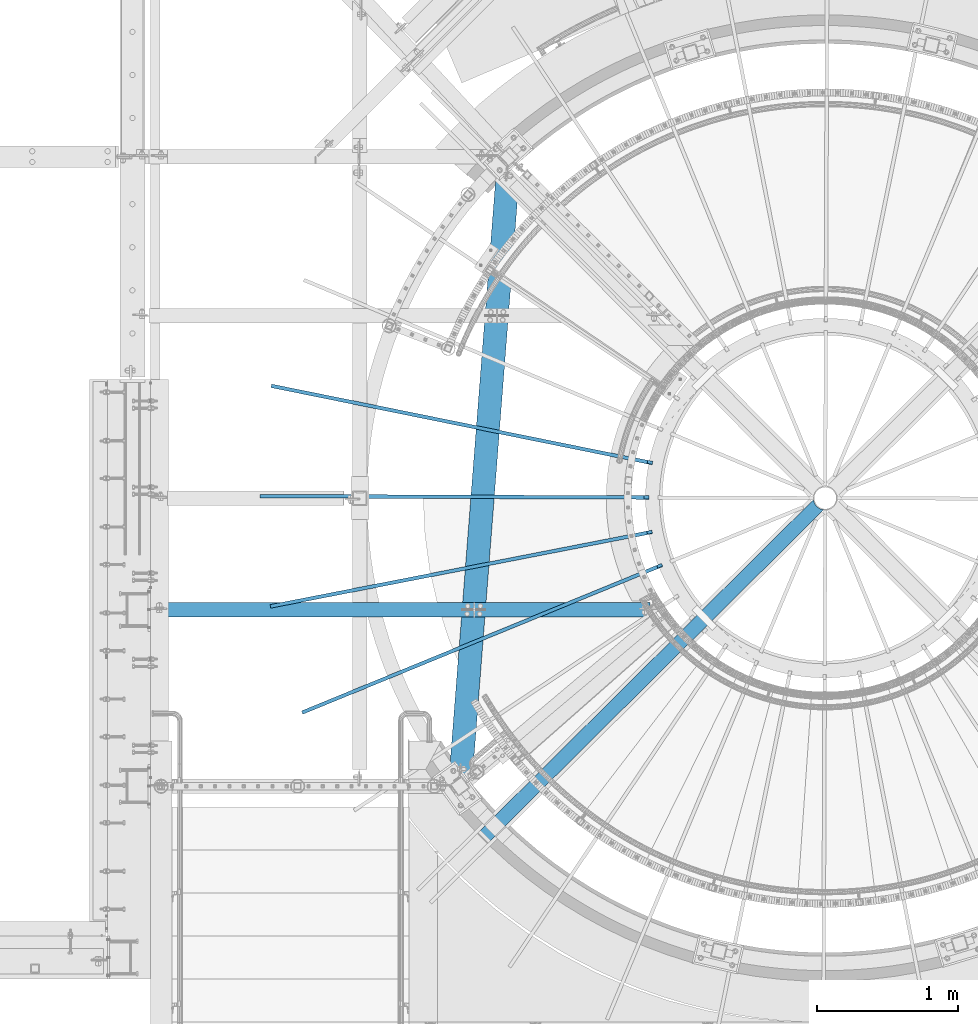
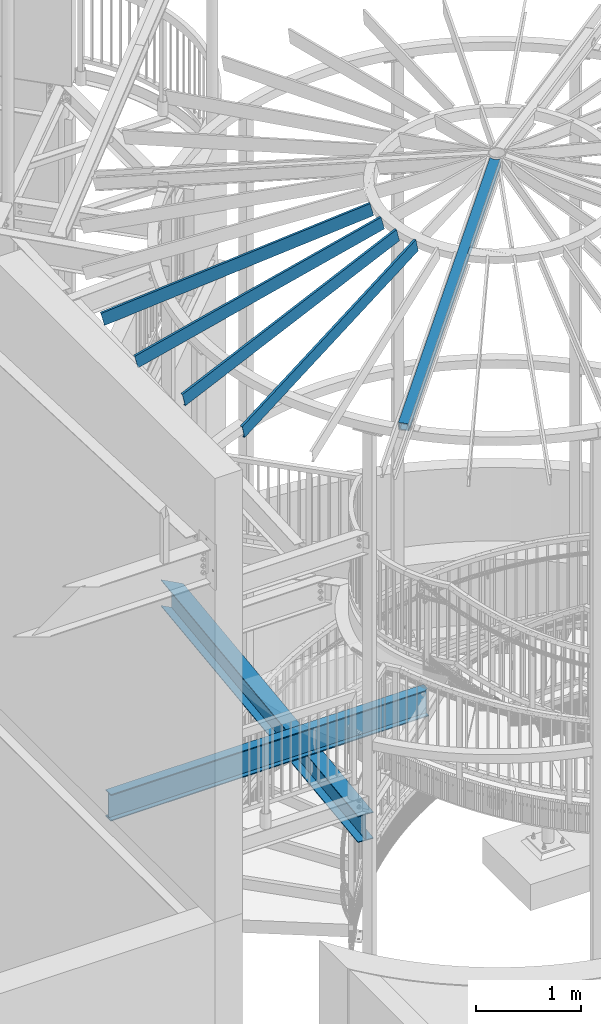
# One storey, part 343 of 975: 7 beams.
"""IFC2X3 building model written with IfcOpenShell, lengths in millimetres."""

import ifcopenshell
import ifcopenshell.guid

model = None  # the IFC model being written
_history = None  # IfcOwnerHistory: only IFC2X3 demands one
_inside = {}  # id of a spatial element -> (the spatial element, [elements in it])
_under = {}  # id of a project, library or spatial element -> (it, [spatial elements below it])
_declared = {}  # id of a project -> (the project, [libraries it declares])
_typed = {}  # id of a type object -> (the type object, [elements of that type])
_made_of = {}  # id of a material, layer set ... -> (it, [elements and type objects made of it])


def new_model(schema):
    """Start an empty IFC model of exactly this schema.

    Asked for "IFC4X3", IfcOpenShell would pick the latest addendum, in which some entities
    have other attributes; the version numbers below select the first issue.
    IFC2X3 requires an IfcOwnerHistory on every rooted entity: one is made here for all.
    """
    global model, _history
    if schema == "IFC4X3":
        model = ifcopenshell.file(schema_version=(4, 3, 0, 0))
    else:
        model = ifcopenshell.file(schema=schema)
    _inside.clear()
    _under.clear()
    _declared.clear()
    _typed.clear()
    _made_of.clear()
    _history = None
    if model.schema == "IFC2X3":
        org = make("IfcOrganization", Name="unknown")
        user = make(
            "IfcPersonAndOrganization",
            ThePerson=make("IfcPerson", FamilyName="unknown"),
            TheOrganization=org,
        )
        app = make(
            "IfcApplication",
            ApplicationDeveloper=org,
            Version="unknown",
            ApplicationFullName="unknown",
            ApplicationIdentifier="unknown",
        )
        _history = make(
            "IfcOwnerHistory",
            OwningUser=user,
            OwningApplication=app,
            ChangeAction="ADDED",
            CreationDate=0,
        )
    return model


def make(cls, **values):
    """One entity of the class cls with the attributes given. An attribute that is None is left unset."""
    return model.create_entity(
        cls, **{name: value for name, value in values.items() if value is not None}
    )


def rooted(cls, **values):
    """An entity with a GlobalId (a new one), such as an element, a storey or a relation."""
    return make(cls, GlobalId=ifcopenshell.guid.new(), OwnerHistory=_history, **values)


def si_unit(unit_type, name, prefix=None):
    """IfcSIUnit, for example si_unit("LENGTHUNIT", "METRE", prefix="MILLI")."""
    return make("IfcSIUnit", UnitType=unit_type, Prefix=prefix, Name=name)


def assignment(units):
    """IfcUnitAssignment: the units of a project."""
    return None if units is None else make("IfcUnitAssignment", Units=units)


def point(xyz):
    """IfcCartesianPoint."""
    return None if xyz is None else make("IfcCartesianPoint", Coordinates=xyz)


def direction(xyz):
    """IfcDirection."""
    return None if xyz is None else make("IfcDirection", DirectionRatios=xyz)


def frame(location, z_axis=None, x_axis=None):
    """IfcAxis2Placement3D, a coordinate frame: its origin and axes. An axis left out is left unset."""
    return make(
        "IfcAxis2Placement3D",
        Location=point(location),
        Axis=direction(z_axis),
        RefDirection=direction(x_axis),
    )


def origin_with_axes():
    """The frame at (0, 0, 0) with the z axis (0, 0, 1) and the x axis (1, 0, 0) written out."""
    return frame((0.0, 0.0, 0.0), z_axis=(0.0, 0.0, 1.0), x_axis=(1.0, 0.0, 0.0))


def place(relative_to, where):
    """IfcLocalPlacement: puts the frame where relative to a parent placement (None: the world)."""
    return make(
        "IfcLocalPlacement", PlacementRelTo=relative_to, RelativePlacement=where
    )


def context(
    kind, dimensions, precision=None, world=None, true_north=None, identifier=None
):
    """IfcGeometricRepresentationContext, for example the 3D "Model" context."""
    return make(
        "IfcGeometricRepresentationContext",
        ContextIdentifier=identifier,
        ContextType=kind,
        CoordinateSpaceDimension=dimensions,
        Precision=precision,
        WorldCoordinateSystem=world,
        TrueNorth=true_north,
    )


def subcontext(parent, identifier, kind, view, scale=None):
    """IfcGeometricRepresentationSubContext, for example "Body" below "Model"."""
    return make(
        "IfcGeometricRepresentationSubContext",
        ContextIdentifier=identifier,
        ContextType=kind,
        ParentContext=parent,
        TargetScale=scale,
        TargetView=view,
    )


def project(units=None, contexts=None):
    """IfcProject with its units and contexts."""
    return rooted(
        "IfcProject",
        Name="project",
        RepresentationContexts=contexts,
        UnitsInContext=assignment(units),
    )


def spatial(cls, under=None, at=None, **own):
    """A site, building, storey or space (cls), placed at a placement, below another one or the project."""
    s = rooted(cls, ObjectPlacement=at, **own)
    if under is not None:
        _under.setdefault(under.id(), (under, []))[1].append(s)
    return s


def faces_of(points, faces, orient=None, outer=None):
    """IfcFace entities. A face is a list of loops; a loop is a list of indices into points, from 0.

    orient and outer hold one flag for each loop. By default every Orientation is true, the
    first loop of a face is its IfcFaceOuterBound and the others are IfcFaceBound.
    """
    made = []
    for i, loops in enumerate(faces):
        bounds = []
        for j, loop in enumerate(loops):
            is_outer = j == 0 if outer is None else outer[i][j]
            bounds.append(
                make(
                    "IfcFaceOuterBound" if is_outer else "IfcFaceBound",
                    Bound=make("IfcPolyLoop", Polygon=[points[k] for k in loop]),
                    Orientation=True if orient is None else orient[i][j],
                )
            )
        made.append(make("IfcFace", Bounds=bounds))
    return made


def faceted_brep(points, faces, orient=None, outer=None, voids=None):
    """IfcFacetedBrep: a solid bounded by flat faces; with voids (closed shells), ...WithVoids."""
    shared = [point(p) for p in points]
    hull = make("IfcClosedShell", CfsFaces=faces_of(shared, faces, orient, outer))
    if voids is None:
        return make("IfcFacetedBrep", Outer=hull)
    return make(
        "IfcFacetedBrepWithVoids",
        Outer=hull,
        Voids=[
            make(cls, CfsFaces=faces_of(shared, fs, o, b)) for cls, fs, o, b in voids
        ],
    )


def shape(context_of_items, identifier, shape_type, items):
    """IfcShapeRepresentation: the items that make up one representation, for example the "Body"."""
    return make(
        "IfcShapeRepresentation",
        ContextOfItems=context_of_items,
        RepresentationIdentifier=identifier,
        RepresentationType=shape_type,
        Items=items,
    )


def material(Name=None, Category=None):
    """IfcMaterial."""
    return make("IfcMaterial", Name=Name, Category=Category)


def made_of(thing, what):
    """Note that an element or type object is made of a material, layer set ...; save() writes the relation."""
    if what is not None:
        _made_of.setdefault(what.id(), (what, []))[1].append(thing)
    return thing


def type_object(cls, material=None, **own):
    """A type object (cls), such as IfcWallType, which elements share."""
    return made_of(rooted(cls, **own), material)


def element(
    cls,
    number,
    at=None,
    inside=None,
    cuts=None,
    type_object=None,
    material=None,
    context=None,
    identifier="Body",
    shape_type=None,
    held_by="IfcProductDefinitionShape",
    body=None,
    shapes=None,
    **own,
):
    """One element of the class cls, such as IfcWall. Its Tag is "e" and its number.

    at: its placement. inside: the storey or other place that contains it. cuts: it is an
    opening in that element (IfcRelVoidsElement). A single representation is given by context,
    identifier, shape_type and body (its items); several are given by shapes. held_by: the class
    of the entity that holds the representations. save() writes the other relations.
    """
    e = rooted(cls, Tag="e%d" % number, ObjectPlacement=at, **own)
    if body is not None:
        shapes = [shape(context, identifier, shape_type, body)]
    if shapes is not None:
        e.Representation = make(held_by, Representations=shapes)
    if inside is not None:
        _inside.setdefault(inside.id(), (inside, []))[1].append(e)
    if cuts is not None:
        rooted(
            "IfcRelVoidsElement", RelatingBuildingElement=cuts, RelatedOpeningElement=e
        )
    if type_object is not None:
        _typed.setdefault(type_object.id(), (type_object, []))[1].append(e)
    return made_of(e, material)


def aggregate(whole, parts):
    """IfcRelAggregates: a whole, such as a stair, and the parts it consists of."""
    return rooted("IfcRelAggregates", RelatingObject=whole, RelatedObjects=parts)


def save(model, path):
    """Write the relations noted so far, then the file.

    IfcRelAggregates (storeys below a building ...), IfcRelContainedInSpatialStructure (elements
    in a storey), IfcRelDefinesByType, IfcRelAssociatesMaterial and IfcRelDeclares: one each for
    every whole, place, type object, material and project.
    """
    for whole, parts in _under.values():
        aggregate(whole, parts)
    for where, things in _inside.values():
        rooted(
            "IfcRelContainedInSpatialStructure",
            RelatedElements=things,
            RelatingStructure=where,
        )
    for kind, things in _typed.values():
        rooted("IfcRelDefinesByType", RelatedObjects=things, RelatingType=kind)
    for what, things in _made_of.values():
        rooted("IfcRelAssociatesMaterial", RelatedObjects=things, RelatingMaterial=what)
    for by, libraries in _declared.values():
        rooted("IfcRelDeclares", RelatingContext=by, RelatedDefinitions=libraries)
    model.write(path)


model = new_model("IFC2X3")

# Units and contexts
model_context = context("Model", 3, precision=1e-05, world=origin_with_axes())
body_context = subcontext(model_context, "Body", "Model", "MODEL_VIEW")
ifc_project = project(units=[si_unit("LENGTHUNIT", "METRE", prefix="MILLI"), si_unit("AREAUNIT", "SQUARE_METRE"), si_unit("VOLUMEUNIT", "CUBIC_METRE"), si_unit("MASSUNIT", "GRAM", prefix="KILO"), si_unit("TIMEUNIT", "SECOND"), si_unit("PLANEANGLEUNIT", "RADIAN"), si_unit("SOLIDANGLEUNIT", "STERADIAN"), si_unit("THERMODYNAMICTEMPERATUREUNIT", "DEGREE_CELSIUS"), si_unit("LUMINOUSINTENSITYUNIT", "LUMEN")], contexts=[model_context])

# Site, building, storey
site_placement = place(None, origin_with_axes())
site = spatial("IfcSite", under=ifc_project, at=site_placement, CompositionType="ELEMENT")
building_placement = place(site_placement, origin_with_axes())
building = spatial("IfcBuilding", under=site, at=building_placement, Name="Undefined", CompositionType="ELEMENT")
storey_placement = place(building_placement, origin_with_axes())
storey = spatial("IfcBuildingStorey", under=building, at=storey_placement, Name="Undefined", CompositionType="ELEMENT", Elevation=0.0)

# Beams
ifc_material_1 = material()
beam_type_1 = type_object("IfcBeamType", Name="HSS4X4X3/8", PredefinedType="NOTDEFINED")
beam_1_placement = place(storey_placement, frame((32317.9344851334, 1004.6786473553, 8355.32707211838), z_axis=(-0.17213026717781, -0.170873527176511, 0.970140922150774), x_axis=(0.688502112820797, 0.683475127155154, 0.242541936995531)))
element("IfcBeam", 1, at=beam_1_placement, inside=storey, type_object=beam_type_1, material=ifc_material_1, Name="BEAM", ObjectType="HSS4X4X3/8", context=body_context, shape_type="Brep", body=[
    faceted_brep([(3438.83735812861, -22.0904176136246, 50.8000000013358), (3436.45604228348, -22.0904176085714, 41.2750000013289), (3433.41640701447, -0.308512534764304, 41.2750000013234), (3435.7977228596, -0.308512539817457, 50.8000000013285), (3436.29143033248, 21.4944170195777, 41.2750000013198), (3438.6727461776, 21.4944170145209, 50.8000000013249), (3454.30560025219, 50.8000000042775, 50.8000000013267), (3447.2664999947, 41.8325374313063, 50.8000000013249), (3421.8657976467, 41.8325374852029, -50.7999999987392), (3428.90489786185, 50.800000004263, -50.7999999987383), (3444.64959996888, 41.2750000042688, 41.275000001317), (3424.01152929259, 41.2750000042543, -41.274999998735), (3415.65335967472, 21.4944170633644, -41.2749999987323), (3413.27204382959, 21.4944170684175, -50.7999999987373), (3412.77833635671, -0.308512490973953, -41.2749999987295), (3410.39702051158, -0.308512485920801, -50.7999999987355), (3415.81797162572, -22.0904175647811, -41.2749999987223), (3413.43665578059, -22.0904175597279, -50.7999999987301), (3454.30536256338, -50.7999999956992, 50.8000000013449), (3428.90466025831, -50.7999999957137, -50.7999999987182), (3422.18380351628, -42.3668973185268, -50.7999999987219), (3447.58450586428, -42.3668973724198, 50.8000000013403), (3424.09408161953, -41.2749999957268, -41.2749999987177), (3444.7321522584, -41.2749999957123, 41.2750000013343), (6.3499999872256, 50.7999999999884, 50.8000000000225), (6.35000001109802, -50.799999999992, 50.8000000000425), (6.34999999362844, -50.7999999999738, -50.8000000000134), (6.34999996975966, 50.8000000000065, -50.8000000000334), (6.34999998782587, 41.2749999999942, 41.2750000000183), (6.35000000721993, -41.2749999999905, 41.2750000000347), (6.34999999302818, -41.274999999976, -41.2750000000101), (6.34999997363047, 41.2750000000087, -41.2750000000256)], [[[0, 1, 2, 3]], [[3, 2, 4, 5]], [[6, 7, 8, 9]], [[5, 4, 10, 11, 12, 13, 8, 7]], [[14, 15, 13, 12]], [[16, 17, 15, 14]], [[18, 19, 20, 21]], [[21, 20, 17, 16, 22, 23, 1, 0]], [[0, 3, 5, 7, 6, 24, 25, 18, 21]], [[26, 27, 9, 8, 13, 15, 17, 20, 19]], [[25, 26, 19, 18]], [[27, 24, 6, 9]], [[26, 25, 24, 27], [28, 29, 30, 31]], [[30, 29, 23, 22]], [[14, 12, 11, 31, 30, 22, 16]], [[28, 31, 11, 10]], [[29, 28, 10, 4, 2, 1, 23]]]),
])
ifc_material_2 = material(Name="STEEL/A992")
beam_type_2 = type_object("IfcBeamType", Name="W12X26", PredefinedType="NOTDEFINED")
beam_2_placement = place(storey_placement, frame((32150.2688578099, 1365.04770757634, 3470.275), z_axis=(0.0, 0.0, 1.0), x_axis=(0.0778020479734672, 0.996968826659658, 0.0)))
element("IfcBeam", 2, at=beam_2_placement, inside=storey, type_object=beam_type_2, material=ifc_material_2, Name="BEAM", ObjectType="W12X26", context=body_context, shape_type="Brep", body=[
    faceted_brep([(84.2955470155048, 82.5500000000757, -155.575), (84.2955470155048, 82.5500000000757, -146.05), (4458.07380512558, 82.5499999984313, -146.05), (4458.07380512558, 82.5499999984313, -155.575), (84.2955470155493, 3.17499999996653, -146.05), (4384.70606070078, 3.17499999834763, -146.05), (84.2955470155493, 3.17499999996653, 146.05), (4384.70606070078, 3.17499999834763, 146.05), (84.2955470155048, 82.5500000000757, 146.05), (4458.07380512558, 82.5499999984313, 146.05), (84.2955470155048, 82.5500000000757, 155.575), (4458.07380512558, 82.5499999984313, 155.575), (84.2955470155971, -82.5500000001484, 155.575), (4305.46889672199, -82.5500000017419, 155.575), (84.2955470155971, -82.5500000001484, 146.05), (4305.46889672199, -82.5500000017419, 146.05), (84.295547015553, -3.17500000004293, 146.05), (4378.83664114679, -3.17500000165819, 146.05), (84.295547015553, -3.17500000004293, -146.05), (4378.83664114679, -3.17500000165819, -146.05), (84.2955470155971, -82.5500000001484, -146.05), (4305.46889672199, -82.5500000017419, -146.05), (84.2955470155971, -82.5500000001484, -155.575), (4305.46889672199, -82.5500000017419, -155.575)], [[[0, 1, 2, 3]], [[1, 4, 5, 2]], [[4, 6, 7, 5]], [[6, 8, 9, 7]], [[8, 10, 11, 9]], [[10, 12, 13, 11]], [[12, 14, 15, 13]], [[14, 16, 17, 15]], [[16, 18, 19, 17]], [[18, 20, 21, 19]], [[20, 22, 23, 21]], [[22, 0, 3, 23]], [[5, 7, 9, 11, 13, 15, 17, 19, 21, 23, 3, 2]], [[22, 20, 18, 16, 14, 12, 10, 8, 6, 4, 1, 0]]]),
])
ifc_material_3 = material(Name="STEEL/Zero_Density")
beam_type_3 = type_object("IfcBeamType", PredefinedType="NOTDEFINED")
for number, where, z_axis, x_axis, name in (
    (3, (33494.0455797955, 3654.71625181728, 8885.0313138005), (-0.237706597905657, 0.0481888419808747, 0.97014092214516), (-0.950800100803031, 0.19275003796007, -0.242541936949755), "STUD"),
    (4, (33563.5871296165, 2923.2359812582, 8885.0313138005), (-0.224418098973874, -0.0919951519892898, 0.970140922167197), (-0.89764757448781, -0.367970434790039, -0.242541936861608), "STUD"),
    (5, (33492.3715209919, 3160.89981011864, 8885.0313138005), (-0.238053331947034, -0.0464456919896647, 0.970140922157455), (-0.952186998609667, -0.185777631923844, -0.242541936900574), "STUD"),
    (6, (33468.8902132218, 3407.8904711684, 8885.0313138005), (-0.242540308898344, 0.000888649999627433, 0.970140922165782), (-0.970134410469096, 0.00355450199805463, -0.242541936867269), "STUD"),
):
    element("IfcBeam", number, at=place(storey_placement, frame(where, z_axis=z_axis, x_axis=x_axis)), inside=storey, type_object=beam_type_3, material=ifc_material_3, Name=name, context=body_context, shape_type="Brep", body=[
        faceted_brep([(-1.67347025126219e-10, 12.6999999998588, -76.2000000000985), (1.96450855582952e-10, 12.7000000001644, 76.2000000001021), (2798.98467503002, 12.7000000041553, 76.2000000028588), (2798.98467502966, 12.7000000038533, -76.1999999973427), (1.74622982740402e-10, -12.6999999998661, 76.2000000000985), (2798.98467503, -12.6999999958753, 76.2000000028534), (1.67347025126219e-10, -12.6999999998698, 73.0250000000947), (2798.98467502999, -12.6999999958789, 73.0250000028504), (1.89174897968769e-10, 9.52500000015425, 73.0250000000974), (2798.98467503001, 9.52500000414511, 73.0250000028532), (-1.60071067512035e-10, 9.52499999986321, -73.0250000000938), (2798.98467502966, 9.52500000385407, -73.0249999973398), (-1.81898940354586e-10, -12.7000000001608, -73.0250000000965), (2798.98467502964, -12.6999999961699, -73.0249999973416), (-1.92812876775861e-10, -12.7000000001717, -76.2000000001003), (2798.98467502963, -12.6999999961772, -76.1999999973455)], [[[0, 1, 2, 3]], [[1, 4, 5, 2]], [[4, 6, 7, 5]], [[6, 8, 9, 7]], [[8, 10, 11, 9]], [[10, 12, 13, 11]], [[12, 14, 15, 13]], [[14, 0, 3, 15]], [[5, 7, 9, 11, 13, 15, 3, 2]], [[14, 12, 10, 8, 6, 4, 1, 0]]]),
    ])
beam_type_4 = type_object("IfcBeamType", Name="W12X22", PredefinedType="NOTDEFINED")
beam_3_placement = place(storey_placement, frame((29959.3, 2612.429687, 3781.425), z_axis=(0.0, 0.0, 1.0), x_axis=(0.999999999995464, -3.01199999726483e-06, 0.0)))
element("IfcBeam", 7, at=beam_3_placement, inside=storey, type_object=beam_type_4, material=ifc_material_2, Name="BEAM", ObjectType="W12X22", context=body_context, shape_type="Brep", body=[
    faceted_brep([(3535.95688591693, -23.8445053418668, 155.575), (3498.92440344849, -50.799999999927, 155.575), (3498.92440344849, -50.799999999927, 144.4625), (3535.95688591693, -23.8445053418668, 144.4625), (25.3999999760817, -3.17499999999973, 144.4625), (25.3999999760817, -3.17499999999973, -144.4625), (3535.9568859169, -3.17499999992697, -144.4625), (3535.9568859169, -3.17499999992697, 144.4625), (25.3999999761254, -50.7999999999993, -144.4625), (3535.95688591694, -50.7999999999261, -144.4625), (25.3999999761254, -50.7999999999993, -155.575), (3535.95688591694, -50.7999999999261, -155.575), (25.3999999760345, 50.8000000000002, -155.575), (3535.95688591685, 50.8000000000729, -155.575), (25.3999999760781, 3.17500000000064, 144.4625), (25.3999999760345, 50.8000000000002, 144.4625), (3535.95688591685, 50.8000000000729, 144.4625), (3535.9568859169, 3.1750000000734, 144.4625), (25.3999999760781, 3.17500000000064, -144.4625), (3535.9568859169, 3.1750000000734, -144.4625), (25.3999999760345, 50.8000000000002, -144.4625), (3535.95688591685, 50.8000000000729, -144.4625), (25.3999999761254, -50.7999999999993, 144.4625), (25.3999999761254, -50.7999999999993, 155.575), (25.3999999760345, 50.8000000000002, 155.575), (3535.95688591685, 50.8000000000729, 155.575)], [[[0, 1, 2, 3]], [[4, 5, 6, 7]], [[5, 8, 9, 6]], [[8, 10, 11, 9]], [[10, 12, 13, 11]], [[14, 15, 16, 17]], [[18, 14, 17, 19]], [[20, 18, 19, 21]], [[12, 20, 21, 13]], [[10, 8, 5, 4, 22, 23, 24, 15, 14, 18, 20, 12]], [[15, 24, 25, 16]], [[7, 6, 9, 11, 13, 21, 19, 17, 16, 25, 0, 3]], [[22, 4, 7, 3, 2]], [[23, 22, 2, 1]], [[25, 24, 23, 1, 0]]]),
])

save(model, "model.ifc")
